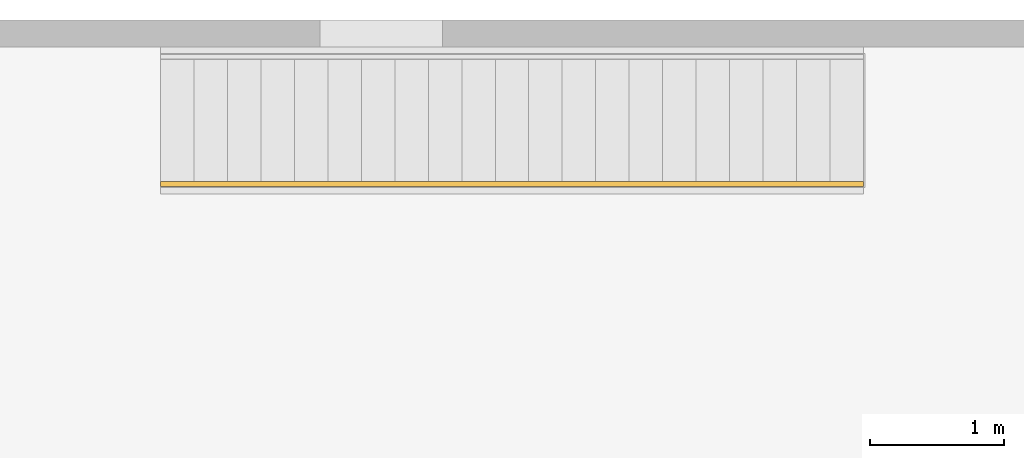
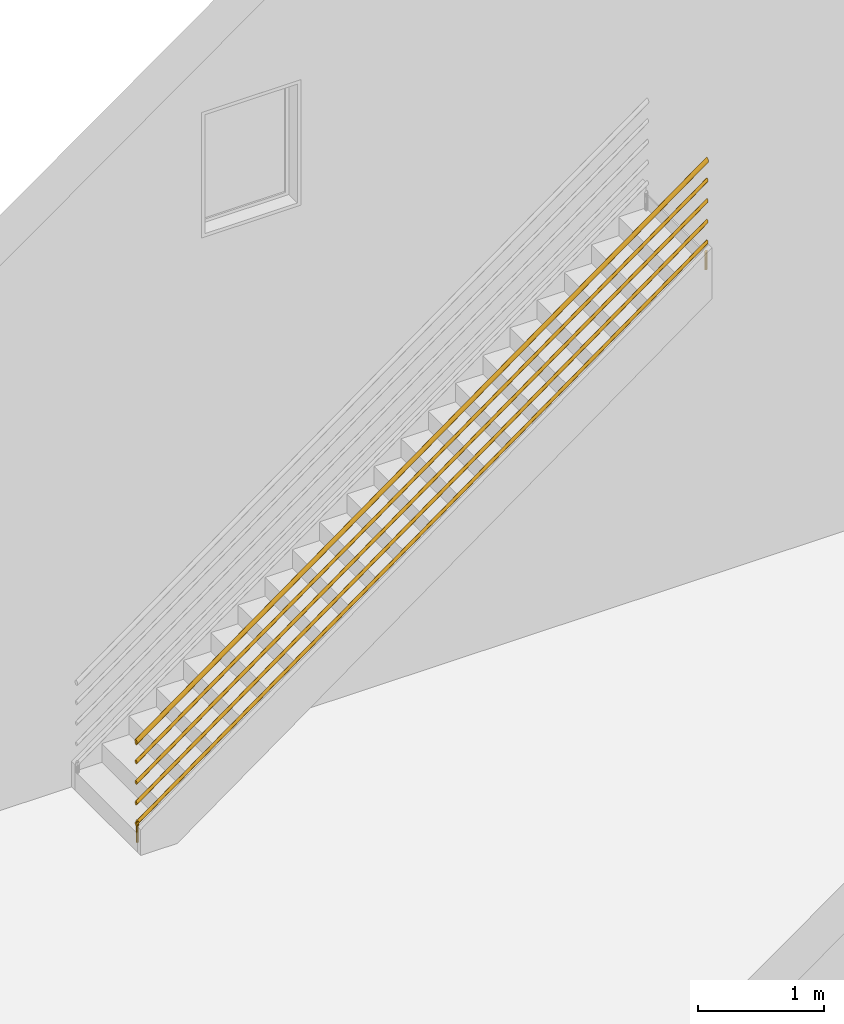
# One storey, part 3 of 4: 1 railing, 1 element without a shape of its own.
"""IFC4 building model written with IfcOpenShell, lengths in millimetres."""

from ifc_helpers import new_model, entity, si_unit, converted_unit, derived_unit, direction, frame, origin, place, context, subcontext, project, spatial, polygons, element, aggregate, save


model = new_model("IFC4")

# Units and contexts
model_context = context("Model", 3, precision=0.01, world=origin(), true_north=direction((6.12303176911189e-17, 1.0)))
body_context = subcontext(model_context, "Body", "Model", "MODEL_VIEW")
ifc_project = project(units=[si_unit("LENGTHUNIT", "METRE", prefix="MILLI"), si_unit("AREAUNIT", "SQUARE_METRE"), si_unit("VOLUMEUNIT", "CUBIC_METRE"), converted_unit("PLANEANGLEUNIT", "DEGREE", entity("IfcRatioMeasure", 0.0174532925199433), si_unit("PLANEANGLEUNIT", "RADIAN"), dimensions=[0, 0, 0, 0, 0, 0, 0]), si_unit("MASSUNIT", "GRAM", prefix="KILO"), derived_unit("MASSDENSITYUNIT", [(si_unit("MASSUNIT", "GRAM", prefix="KILO"), 1), (si_unit("LENGTHUNIT", "METRE"), -3)]), si_unit("TIMEUNIT", "SECOND"), si_unit("FREQUENCYUNIT", "HERTZ"), si_unit("THERMODYNAMICTEMPERATUREUNIT", "DEGREE_CELSIUS"), derived_unit("THERMALTRANSMITTANCEUNIT", [(si_unit("MASSUNIT", "GRAM", prefix="KILO"), 1), (si_unit("THERMODYNAMICTEMPERATUREUNIT", "KELVIN"), -1), (si_unit("TIMEUNIT", "SECOND"), -3)]), derived_unit("VOLUMETRICFLOWRATEUNIT", [(si_unit("LENGTHUNIT", "METRE"), 3), (si_unit("TIMEUNIT", "SECOND"), -1)]), si_unit("ELECTRICCURRENTUNIT", "AMPERE"), si_unit("ELECTRICVOLTAGEUNIT", "VOLT"), si_unit("POWERUNIT", "WATT"), si_unit("FORCEUNIT", "NEWTON", prefix="KILO"), si_unit("ILLUMINANCEUNIT", "LUX"), si_unit("LUMINOUSFLUXUNIT", "LUMEN"), si_unit("LUMINOUSINTENSITYUNIT", "CANDELA"), derived_unit("USERDEFINED", [(si_unit("MASSUNIT", "GRAM", prefix="KILO"), -1), (si_unit("LENGTHUNIT", "METRE"), -2), (si_unit("TIMEUNIT", "SECOND"), 3), (si_unit("LUMINOUSFLUXUNIT", "LUMEN"), 1)]), derived_unit("LINEARVELOCITYUNIT", [(si_unit("LENGTHUNIT", "METRE"), 1), (si_unit("TIMEUNIT", "SECOND"), -1)]), si_unit("PRESSUREUNIT", "PASCAL"), derived_unit("USERDEFINED", [(si_unit("LENGTHUNIT", "METRE"), -2), (si_unit("MASSUNIT", "GRAM", prefix="KILO"), 1), (si_unit("TIMEUNIT", "SECOND"), -2)])], contexts=[model_context])

# Site, building, storey
site_placement = place(None, origin())
site = spatial("IfcSite", under=ifc_project, at=site_placement, CompositionType="ELEMENT")
building_placement = place(site_placement, origin())
building = spatial("IfcBuilding", under=site, at=building_placement, CompositionType="ELEMENT")
storey_placement = place(building_placement, origin())
storey = spatial("IfcBuildingStorey", under=building, at=storey_placement, CompositionType="ELEMENT", Elevation=0.0)

# Stair, railing
stair_placement = place(storey_placement, origin())
stair = element("IfcStair", 1, at=stair_placement, inside=storey, Name="Assembled Stair:Stair", PredefinedType="NOTDEFINED")
railing_placement = place(stair_placement, frame((-1616.29690804862, 2834.11152440017, 81.8181818181819)))
railing = element("IfcRailing", 2, at=railing_placement, Name="Railing:900mm", ObjectType="Railing:900mm", PredefinedType="NOTDEFINED", context=body_context, shape_type="Tessellation", body=[
    polygons([(5238.77409890227, 9.09527223591636, 3909.09090909091), (5238.77409890227, 9.09527223591636, 3736.36363636364), (5245.02409890227, 10.7699546886106, 3736.36363636364), (5249.59941644958, 15.345272235916, 3736.36363636364), (5251.27409890227, 21.5952722359162, 3736.36363636364), (5249.59941644958, 27.8452722359159, 3736.36363636364), (5245.02409890227, 32.4205897832218, 3736.36363636364), (5238.77409890227, 34.0952722359161, 3736.36363636364), (5238.77409890227, 34.0952722359161, 3909.09090909091), (5244.19764564124, 32.8573830846962, 3913.03530671925), (5248.54699243312, 29.38889475915, 3916.19846802244), (5250.96069780455, 24.3767839103697, 3917.95389011074), (5250.96069780455, 18.8137605614622, 3917.95389011074), (5248.54699243312, 13.8016497126819, 3916.19846802244), (5244.19764564124, 10.3331613871357, 3913.03530671925), (5233.3505521633, 10.3331613871363, 3905.14651146257), (5229.00120537142, 13.8016497126819, 3901.98335015938), (5226.5875, 18.8137605614622, 3900.22792807107), (5226.5875, 24.3767839103703, 3900.22792807107), (5229.00120537142, 29.3888947591506, 3901.98335015938), (5233.3505521633, 32.8573830846962, 3905.14651146257), (5232.52409890227, 32.4205897832218, 3736.36363636364), (5227.94878135497, 27.8452722359164, 3736.36363636364), (5226.27409890227, 21.5952722359162, 3736.36363636364), (5227.94878135497, 15.345272235916, 3736.36363636364), (5232.52409890227, 10.7699546886106, 3736.36363636364)], [[[3, 4, 15]], [[2, 3, 1]], [[1, 3, 15]], [[23, 22, 8, 7, 6, 5, 4, 3, 2, 26, 25, 24]], [[14, 15, 4]], [[13, 14, 4]], [[4, 5, 13]], [[21, 20, 19, 18, 17, 16, 1, 15, 14, 13, 12, 11, 10, 9]], [[16, 26, 2]], [[1, 16, 2]], [[5, 12, 13]], [[12, 5, 6]], [[12, 6, 11]], [[10, 6, 7]], [[11, 6, 10]], [[7, 8, 9]], [[7, 9, 10]], [[8, 22, 21]], [[21, 9, 8]], [[22, 23, 20]], [[21, 22, 20]], [[19, 20, 23]], [[23, 24, 19]], [[24, 18, 19]], [[18, 24, 25]], [[17, 18, 25]], [[17, 25, 26]], [[17, 26, 16]]], closed=True),
    polygons([(13.7740989022728, 34.0952722359329, 209.09090909091), (19.1976456412423, 32.857383084713, 209.09090909091), (23.5469924331231, 29.3888947591674, 209.09090909091), (25.9606978045457, 24.376783910387, 209.09090909091), (25.9606978045457, 18.813760561479, 209.09090909091), (23.5469924331231, 13.8016497126987, 209.09090909091), (19.1976456412423, 10.3331613871525, 209.09090909091), (13.7740989022728, 9.09527223593314, 209.09090909091), (13.7740989022728, 9.09527223593314, -1.69197988952874e-14), (19.1976456412423, 10.3331613871525, -1.69197988952874e-14), (23.5469924331231, 13.8016497126987, -1.69197988952874e-14), (25.9606978045457, 18.813760561479, -1.69197988952874e-14), (25.9606978045457, 24.376783910387, -1.69197988952874e-14), (23.5469924331231, 29.3888947591674, -1.69197988952874e-14), (19.1976456412423, 32.857383084713, -1.69197988952874e-14), (13.7740989022728, 34.0952722359329, -1.69197988952874e-14), (8.3505521633033, 10.333161387153, 209.09090909091), (4.00120537142245, 13.8016497126987, 209.09090909091), (1.58749999999991, 18.813760561479, 209.09090909091), (1.58749999999991, 24.376783910387, 209.09090909091), (4.00120537142245, 29.3888947591674, 209.09090909091), (8.3505521633033, 32.8573830847135, 209.09090909091), (8.3505521633033, 32.8573830847135, -1.69197988952874e-14), (4.00120537142245, 29.3888947591674, -1.69197988952874e-14), (1.58749999999991, 24.376783910387, -1.69197988952874e-14), (1.58749999999991, 18.813760561479, -1.69197988952874e-14), (4.00120537142245, 13.8016497126987, -1.69197988952874e-14), (8.3505521633033, 10.333161387153, -1.69197988952874e-14)], [[[8, 9, 10, 7]], [[17, 28, 9, 8]], [[18, 17, 8, 7, 6, 5, 4, 3, 2, 1, 22, 21, 20, 19]], [[26, 25, 24, 23, 16, 15, 14, 13, 12, 11, 10, 9, 28, 27]], [[7, 10, 11, 6]], [[11, 12, 5, 6]], [[12, 13, 4, 5]], [[4, 13, 14, 3]], [[3, 14, 15, 2]], [[2, 15, 16, 1]], [[22, 1, 16, 23]], [[23, 24, 21, 22]], [[25, 20, 21, 24]], [[25, 26, 19, 20]], [[19, 26, 27, 18]], [[18, 27, 28, 17]]], closed=True),
    polygons([(1.27409890227292, 36.5952722359328, 781.452540215361), (1.27409890227292, 36.0841596302689, 776.652104384823), (1.27409890227292, 34.5856532926994, 772.178810323041), (1.27409890227292, 32.2018739537314, 768.337505627858), (1.27409890227292, 29.0952722359329, 765.389968866193), (1.27409890227292, 25.4775579124705, 763.53706979732), (1.27409890227292, 21.595272235933, 762.905080430722), (1.27409890227292, 17.712986559395, 763.53706979732), (1.27409890227292, 14.0952722359331, 765.389968866194), (1.27409890227292, 10.9886705181346, 768.337505627858), (1.27409890227292, 8.60489117916664, 772.178810323042), (1.27409890227292, 7.10638484159716, 776.652104384824), (1.27409890227292, 6.59527223593317, 781.452540215361), (1.27409890227292, 7.10638484159716, 786.252976045899), (1.27409890227292, 8.60489117916664, 790.726270107681), (1.27409890227292, 10.9886705181346, 794.567574802864), (1.27409890227292, 14.0952722359331, 797.515111564529), (1.27409890227292, 17.712986559395, 799.368010633402), (1.27409890227292, 21.595272235933, 800.0), (1.27409890227292, 25.477557912471, 799.368010633402), (1.27409890227292, 29.0952722359329, 797.515111564529), (1.27409890227292, 32.2018739537314, 794.567574802864), (1.27409890227292, 34.5856532926994, 790.726270107681), (1.27409890227292, 36.0841596302689, 786.252976045899), (5251.27409890227, 36.5952722359161, 4599.63435839718), (5251.27409890227, 36.0841596302521, 4604.43479422772), (5251.27409890227, 34.5856532926826, 4608.9080882895), (5251.27409890227, 32.2018739537146, 4612.74939298468), (5251.27409890227, 29.0952722359161, 4615.69692974635), (5251.27409890227, 25.4775579124542, 4617.54982881522), (5251.27409890227, 21.5952722359162, 4618.18181818182), (5251.27409890227, 17.7129865593782, 4617.54982881522), (5251.27409890227, 14.0952722359163, 4615.69692974635), (5251.27409890227, 10.9886705181179, 4612.74939298468), (5251.27409890227, 8.60489117914986, 4608.9080882895), (5251.27409890227, 7.10638484158038, 4604.43479422772), (5251.27409890227, 6.59527223591639, 4599.63435839718), (5251.27409890227, 7.10638484158038, 4594.83392256664), (5251.27409890227, 8.60489117914986, 4590.36062850486), (5251.27409890227, 10.9886705181179, 4586.51932380968), (5251.27409890227, 14.0952722359163, 4583.57178704801), (5251.27409890227, 17.7129865593782, 4581.71888797914), (5251.27409890227, 21.5952722359162, 4581.08689861254), (5251.27409890227, 25.4775579124537, 4581.71888797914), (5251.27409890227, 29.0952722359161, 4583.57178704801), (5251.27409890227, 32.2018739537146, 4586.51932380968), (5251.27409890227, 34.5856532926826, 4590.36062850486), (5251.27409890227, 36.0841596302521, 4594.83392256664)], [[[13, 14, 15, 16, 17, 18, 19, 20, 21, 22, 23, 24, 1, 2, 3, 4, 5, 6, 7, 8, 9, 10, 11, 12]], [[39, 38, 12, 11]], [[38, 37, 13, 12]], [[48, 47, 3, 2]], [[25, 48, 2, 1]], [[40, 39, 11, 10]], [[46, 45, 5, 4]], [[47, 46, 4, 3]], [[41, 40, 10, 9]], [[45, 44, 6, 5]], [[42, 8, 7, 43]], [[42, 41, 9, 8]], [[43, 7, 6, 44]], [[1, 24, 26, 25]], [[36, 14, 13, 37]], [[29, 28, 22, 21]], [[23, 27, 26, 24]], [[22, 28, 27, 23]], [[35, 15, 14, 36]], [[35, 34, 16, 15]], [[17, 16, 34, 33]], [[18, 17, 33, 32]], [[19, 18, 32, 31]], [[19, 31, 30, 20]], [[29, 21, 20, 30]], [[32, 33, 34, 35, 36, 37, 38, 39, 40, 41, 42, 43, 44, 45, 46, 47, 48, 25, 26, 27, 28, 29, 30, 31]]], closed=True),
    polygons([(1.27409890227292, 36.5952722359328, 581.452540215361), (1.27409890227292, 36.0841596302689, 576.652104384823), (1.27409890227292, 34.5856532926994, 572.178810323042), (1.27409890227292, 32.2018739537314, 568.337505627858), (1.27409890227292, 29.0952722359329, 565.389968866193), (1.27409890227292, 25.4775579124705, 563.53706979732), (1.27409890227292, 21.595272235933, 562.905080430722), (1.27409890227292, 17.712986559395, 563.53706979732), (1.27409890227292, 14.0952722359331, 565.389968866194), (1.27409890227292, 10.9886705181346, 568.337505627858), (1.27409890227292, 8.60489117916664, 572.178810323042), (1.27409890227292, 7.10638484159716, 576.652104384824), (1.27409890227292, 6.59527223593317, 581.452540215361), (1.27409890227292, 7.10638484159716, 586.252976045899), (1.27409890227292, 8.60489117916664, 590.726270107681), (1.27409890227292, 10.9886705181346, 594.567574802864), (1.27409890227292, 14.0952722359331, 597.515111564529), (1.27409890227292, 17.712986559395, 599.368010633402), (1.27409890227292, 21.595272235933, 600.0), (1.27409890227292, 25.477557912471, 599.368010633402), (1.27409890227292, 29.0952722359329, 597.515111564529), (1.27409890227292, 32.2018739537314, 594.567574802864), (1.27409890227292, 34.5856532926994, 590.726270107681), (1.27409890227292, 36.0841596302689, 586.252976045899), (5251.27409890227, 36.5952722359161, 4399.63435839718), (5251.27409890227, 36.0841596302521, 4404.43479422772), (5251.27409890227, 34.5856532926826, 4408.9080882895), (5251.27409890227, 32.2018739537146, 4412.74939298468), (5251.27409890227, 29.0952722359161, 4415.69692974635), (5251.27409890227, 25.4775579124542, 4417.54982881522), (5251.27409890227, 21.5952722359162, 4418.18181818182), (5251.27409890227, 17.7129865593782, 4417.54982881522), (5251.27409890227, 14.0952722359163, 4415.69692974635), (5251.27409890227, 10.9886705181179, 4412.74939298468), (5251.27409890227, 8.60489117914986, 4408.9080882895), (5251.27409890227, 7.10638484158038, 4404.43479422772), (5251.27409890227, 6.59527223591639, 4399.63435839718), (5251.27409890227, 7.10638484158038, 4394.83392256664), (5251.27409890227, 8.60489117914986, 4390.36062850486), (5251.27409890227, 10.9886705181179, 4386.51932380968), (5251.27409890227, 14.0952722359163, 4383.57178704801), (5251.27409890227, 17.7129865593782, 4381.71888797914), (5251.27409890227, 21.5952722359162, 4381.08689861254), (5251.27409890227, 25.4775579124537, 4381.71888797914), (5251.27409890227, 29.0952722359161, 4383.57178704801), (5251.27409890227, 32.2018739537146, 4386.51932380968), (5251.27409890227, 34.5856532926826, 4390.36062850486), (5251.27409890227, 36.0841596302521, 4394.83392256664)], [[[13, 14, 15, 16, 17, 18, 19, 20, 21, 22, 23, 24, 1, 2, 3, 4, 5, 6, 7, 8, 9, 10, 11, 12]], [[39, 38, 12, 11]], [[38, 37, 13, 12]], [[48, 47, 3, 2]], [[25, 48, 2, 1]], [[40, 39, 11, 10]], [[47, 46, 4, 3]], [[41, 40, 10, 9]], [[45, 44, 6, 5]], [[42, 8, 7, 43]], [[42, 41, 9, 8]], [[43, 7, 6, 44]], [[46, 45, 5, 4]], [[1, 24, 26, 25]], [[36, 14, 13, 37]], [[29, 28, 22, 21]], [[23, 27, 26, 24]], [[22, 28, 27, 23]], [[35, 15, 14, 36]], [[35, 34, 16, 15]], [[17, 16, 34, 33]], [[18, 17, 33, 32]], [[19, 18, 32, 31]], [[19, 31, 30, 20]], [[29, 21, 20, 30]], [[32, 33, 34, 35, 36, 37, 38, 39, 40, 41, 42, 43, 44, 45, 46, 47, 48, 25, 26, 27, 28, 29, 30, 31]]], closed=True),
    polygons([(1.27409890227292, 36.5952722359328, 381.452540215361), (1.27409890227292, 36.0841596302689, 376.652104384823), (1.27409890227292, 34.5856532926994, 372.178810323041), (1.27409890227292, 32.2018739537314, 368.337505627858), (1.27409890227292, 29.0952722359329, 365.389968866193), (1.27409890227292, 25.4775579124705, 363.53706979732), (1.27409890227292, 21.595272235933, 362.905080430722), (1.27409890227292, 17.712986559395, 363.53706979732), (1.27409890227292, 14.0952722359331, 365.389968866193), (1.27409890227292, 10.9886705181346, 368.337505627858), (1.27409890227292, 8.60489117916664, 372.178810323042), (1.27409890227292, 7.10638484159716, 376.652104384824), (1.27409890227292, 6.59527223593317, 381.452540215361), (1.27409890227292, 7.10638484159716, 386.252976045899), (1.27409890227292, 8.60489117916664, 390.726270107681), (1.27409890227292, 10.9886705181346, 394.567574802864), (1.27409890227292, 14.0952722359331, 397.515111564529), (1.27409890227292, 17.712986559395, 399.368010633402), (1.27409890227292, 21.595272235933, 400.0), (1.27409890227292, 25.477557912471, 399.368010633402), (1.27409890227292, 29.0952722359329, 397.515111564529), (1.27409890227292, 32.2018739537314, 394.567574802864), (1.27409890227292, 34.5856532926994, 390.726270107681), (1.27409890227292, 36.0841596302689, 386.252976045899), (5251.27409890227, 36.5952722359161, 4199.63435839718), (5251.27409890227, 36.0841596302521, 4204.43479422772), (5251.27409890227, 34.5856532926826, 4208.9080882895), (5251.27409890227, 32.2018739537146, 4212.74939298468), (5251.27409890227, 29.0952722359161, 4215.69692974635), (5251.27409890227, 25.4775579124542, 4217.54982881522), (5251.27409890227, 21.5952722359162, 4218.18181818182), (5251.27409890227, 17.7129865593782, 4217.54982881522), (5251.27409890227, 14.0952722359163, 4215.69692974635), (5251.27409890227, 10.9886705181179, 4212.74939298468), (5251.27409890227, 8.60489117914986, 4208.9080882895), (5251.27409890227, 7.10638484158038, 4204.43479422772), (5251.27409890227, 6.59527223591639, 4199.63435839718), (5251.27409890227, 7.10638484158038, 4194.83392256664), (5251.27409890227, 8.60489117914986, 4190.36062850486), (5251.27409890227, 10.9886705181179, 4186.51932380968), (5251.27409890227, 14.0952722359163, 4183.57178704801), (5251.27409890227, 17.7129865593782, 4181.71888797914), (5251.27409890227, 21.5952722359162, 4181.08689861254), (5251.27409890227, 25.4775579124537, 4181.71888797914), (5251.27409890227, 29.0952722359161, 4183.57178704801), (5251.27409890227, 32.2018739537146, 4186.51932380968), (5251.27409890227, 34.5856532926826, 4190.36062850486), (5251.27409890227, 36.0841596302521, 4194.83392256664)], [[[23, 27, 26, 24]], [[39, 38, 12, 11]], [[38, 37, 13, 12]], [[48, 47, 3, 2]], [[25, 48, 2, 1]], [[40, 39, 11, 10]], [[46, 45, 5, 4]], [[47, 46, 4, 3]], [[41, 40, 10, 9]], [[45, 44, 6, 5]], [[42, 8, 7, 43]], [[42, 41, 9, 8]], [[43, 7, 6, 44]], [[1, 24, 26, 25]], [[36, 14, 13, 37]], [[18, 19, 20, 21, 22, 23, 24, 1, 2, 3, 4, 5, 6, 7, 8, 9, 10, 11, 12, 13, 14, 15, 16, 17]], [[22, 28, 27, 23]], [[29, 28, 22, 21]], [[35, 15, 14, 36]], [[35, 34, 16, 15]], [[17, 16, 34, 33]], [[29, 21, 20, 30]], [[18, 17, 33, 32]], [[19, 18, 32, 31]], [[19, 31, 30, 20]], [[32, 33, 34, 35, 36, 37, 38, 39, 40, 41, 42, 43, 44, 45, 46, 47, 48, 25, 26, 27, 28, 29, 30, 31]]], closed=True),
    polygons([(1.27409890227292, 36.5952722359334, 181.452540215361), (1.27409890227292, 36.0841596302694, 176.652104384823), (1.27409890227292, 34.5856532926999, 172.178810323041), (1.27409890227292, 32.2018739537319, 168.337505627858), (1.27409890227292, 29.0952722359335, 165.389968866193), (1.27409890227292, 25.477557912471, 163.53706979732), (1.27409890227292, 21.5952722359336, 162.905080430722), (1.27409890227292, 17.7129865593955, 163.53706979732), (1.27409890227292, 14.0952722359336, 165.389968866193), (1.27409890227292, 10.9886705181352, 168.337505627858), (1.27409890227292, 8.60489117916718, 172.178810323041), (1.27409890227292, 7.10638484159771, 176.652104384823), (1.27409890227292, 6.59527223593371, 181.452540215361), (1.27409890227292, 7.10638484159771, 186.252976045899), (1.27409890227292, 8.60489117916718, 190.72627010768), (1.27409890227292, 10.9886705181352, 194.567574802864), (1.27409890227292, 14.0952722359336, 197.515111564529), (1.27409890227292, 17.7129865593955, 199.368010633402), (1.27409890227292, 21.5952722359336, 200.0), (1.27409890227292, 25.4775579124716, 199.368010633402), (1.27409890227292, 29.0952722359335, 197.515111564529), (1.27409890227292, 32.2018739537319, 194.567574802864), (1.27409890227292, 34.5856532926999, 190.72627010768), (1.27409890227292, 36.0841596302694, 186.252976045898), (5251.27409890227, 36.5952722359166, 3999.63435839718), (5251.27409890227, 36.0841596302526, 4004.43479422772), (5251.27409890227, 34.5856532926831, 4008.9080882895), (5251.27409890227, 32.2018739537151, 4012.74939298468), (5251.27409890227, 29.0952722359167, 4015.69692974635), (5251.27409890227, 25.4775579124548, 4017.54982881522), (5251.27409890227, 21.5952722359168, 4018.18181818182), (5251.27409890227, 17.7129865593788, 4017.54982881522), (5251.27409890227, 14.0952722359168, 4015.69692974635), (5251.27409890227, 10.9886705181184, 4012.74939298468), (5251.27409890227, 8.6048911791504, 4008.9080882895), (5251.27409890227, 7.10638484158092, 4004.43479422772), (5251.27409890227, 6.59527223591693, 3999.63435839718), (5251.27409890227, 7.10638484158092, 3994.83392256664), (5251.27409890227, 8.6048911791504, 3990.36062850486), (5251.27409890227, 10.9886705181184, 3986.51932380968), (5251.27409890227, 14.0952722359168, 3983.57178704801), (5251.27409890227, 17.7129865593788, 3981.71888797914), (5251.27409890227, 21.5952722359168, 3981.08689861254), (5251.27409890227, 25.4775579124542, 3981.71888797914), (5251.27409890227, 29.0952722359167, 3983.57178704801), (5251.27409890227, 32.2018739537151, 3986.51932380968), (5251.27409890227, 34.5856532926831, 3990.36062850486), (5251.27409890227, 36.0841596302526, 3994.83392256664)], [[[13, 14, 15, 16, 17, 18, 19, 20, 21, 22, 23, 24, 1, 2, 3, 4, 5, 6, 7, 8, 9, 10, 11, 12]], [[39, 38, 12, 11]], [[38, 37, 13, 12]], [[48, 47, 3, 2]], [[25, 48, 2, 1]], [[40, 39, 11, 10]], [[46, 45, 5, 4]], [[47, 46, 4, 3]], [[41, 40, 10, 9]], [[45, 44, 6, 5]], [[42, 8, 7, 43]], [[42, 41, 9, 8]], [[43, 7, 6, 44]], [[1, 24, 26, 25]], [[36, 14, 13, 37]], [[29, 28, 22, 21]], [[23, 27, 26, 24]], [[22, 28, 27, 23]], [[35, 15, 14, 36]], [[35, 34, 16, 15]], [[17, 16, 34, 33]], [[18, 17, 33, 32]], [[19, 18, 32, 31]], [[19, 31, 30, 20]], [[29, 21, 20, 30]], [[32, 33, 34, 35, 36, 37, 38, 39, 40, 41, 42, 43, 44, 45, 46, 47, 48, 25, 26, 27, 28, 29, 30, 31]]], closed=True),
    polygons([(1.27409890227292, 1.59527223593323, 975.270053620481), (1.27409890227292, 2.27675571015188, 981.670634727865), (1.27409890227292, 4.27476416024398, 987.635026810241), (1.27409890227292, 7.4531366122022, 992.756766403819), (1.27409890227292, 11.5952722359331, 996.686815419372), (1.27409890227292, 16.4188913338827, 999.157347511203), (1.27409890227292, 21.595272235933, 1000.0), (1.27409890227292, 26.7716531379833, 999.157347511203), (1.27409890227292, 31.5952722359329, 996.686815419372), (1.27409890227292, 35.7374078596638, 992.756766403819), (1.27409890227292, 38.9157803116215, 987.635026810241), (1.27409890227292, 40.9137887617141, 981.670634727865), (1.27409890227292, 41.5952722359328, 975.270053620482), (1.27409890227292, 40.9137887617147, 968.869472513098), (1.27409890227292, 38.915780311622, 962.905080430722), (1.27409890227292, 35.7374078596644, 957.783340837144), (1.27409890227292, 31.5952722359329, 953.853291821591), (1.27409890227292, 26.7716531379833, 951.38275972976), (1.27409890227292, 21.595272235933, 950.540107240963), (1.27409890227292, 16.4188913338827, 951.38275972976), (1.27409890227292, 11.5952722359331, 953.853291821591), (1.27409890227292, 7.4531366122022, 957.783340837144), (1.27409890227292, 4.27476416024452, 962.905080430722), (1.27409890227292, 2.27675571015188, 968.869472513098), (5251.27409890227, 1.59527223591644, 4793.4518718023), (5251.27409890227, 2.2767557101351, 4787.05129069492), (5251.27409890227, 4.27476416022773, 4781.08689861254), (5251.27409890227, 7.45313661218542, 4775.96515901896), (5251.27409890227, 11.5952722359163, 4772.03511000341), (5251.27409890227, 16.4188913338659, 4769.56457791158), (5251.27409890227, 21.5952722359162, 4768.72192542278), (5251.27409890227, 26.7716531379665, 4769.56457791158), (5251.27409890227, 31.5952722359161, 4772.03511000341), (5251.27409890227, 35.7374078596476, 4775.96515901896), (5251.27409890227, 38.9157803116053, 4781.08689861254), (5251.27409890227, 40.9137887616979, 4787.05129069492), (5251.27409890227, 41.595272235916, 4793.4518718023), (5251.27409890227, 40.9137887616974, 4799.85245290968), (5251.27409890227, 38.9157803116047, 4805.81684499206), (5251.27409890227, 35.737407859647, 4810.93858458564), (5251.27409890227, 31.5952722359161, 4814.86863360119), (5251.27409890227, 26.7716531379665, 4817.33916569302), (5251.27409890227, 21.5952722359162, 4818.18181818182), (5251.27409890227, 16.4188913338659, 4817.33916569302), (5251.27409890227, 11.5952722359163, 4814.86863360119), (5251.27409890227, 7.45313661218542, 4810.93858458564), (5251.27409890227, 4.27476416022719, 4805.81684499206), (5251.27409890227, 2.2767557101351, 4799.85245290968)], [[[20, 21, 22, 23, 24, 1, 2, 3, 4, 5, 6, 7, 8, 9, 10, 11, 12, 13, 14, 15, 16, 17, 18, 19]], [[27, 26, 24, 23]], [[26, 25, 1, 24]], [[35, 34, 16, 15]], [[36, 35, 15, 14]], [[28, 27, 23, 22]], [[34, 33, 17, 16]], [[29, 28, 22, 21]], [[33, 32, 18, 17]], [[30, 20, 19, 31]], [[30, 29, 21, 20]], [[13, 12, 38, 37]], [[37, 36, 14, 13]], [[48, 2, 1, 25]], [[41, 40, 10, 9]], [[11, 39, 38, 12]], [[10, 40, 39, 11]], [[47, 3, 2, 48]], [[47, 46, 4, 3]], [[5, 4, 46, 45]], [[6, 5, 45, 44]], [[7, 6, 44, 43]], [[7, 43, 42, 8]], [[41, 9, 8, 42]], [[31, 19, 18, 32]], [[44, 45, 46, 47, 48, 25, 26, 27, 28, 29, 30, 31, 32, 33, 34, 35, 36, 37, 38, 39, 40, 41, 42, 43]]], closed=True),
])
aggregate(stair, [railing])

save(model, "model.ifc")
